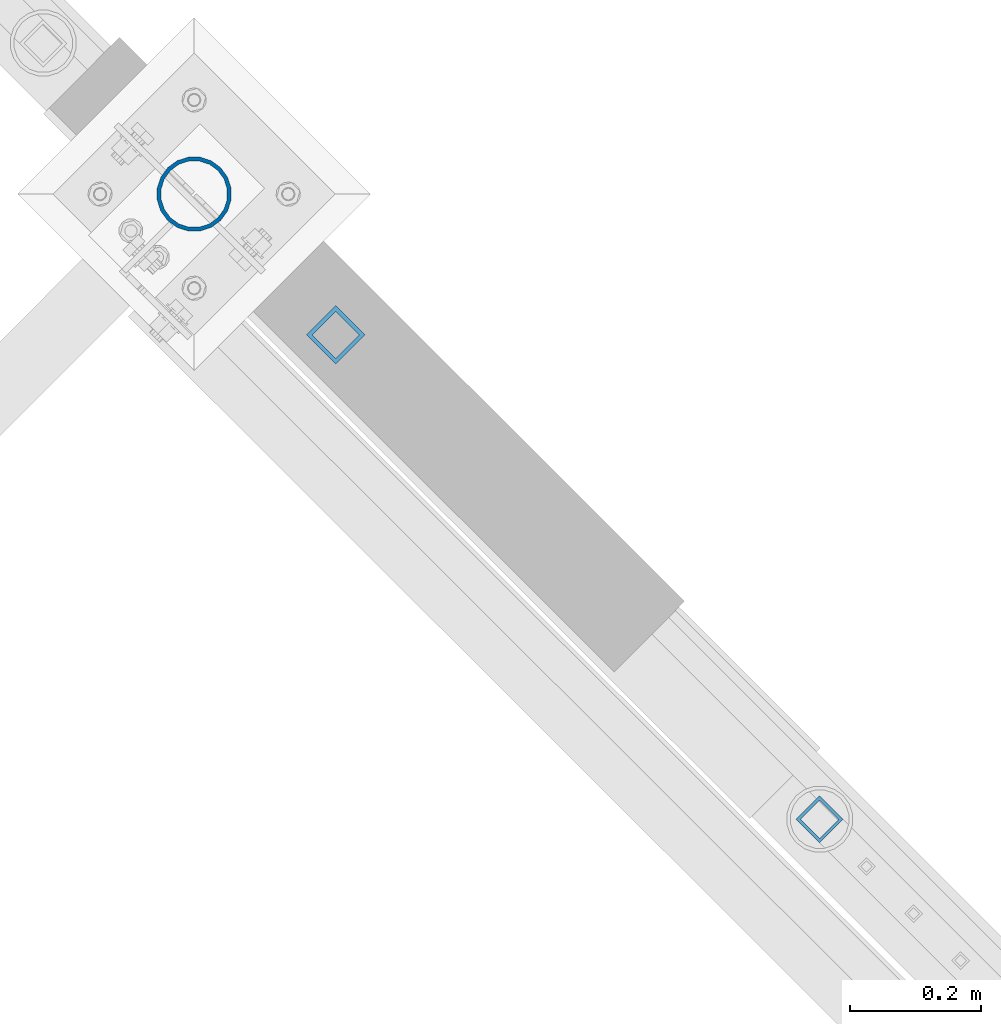
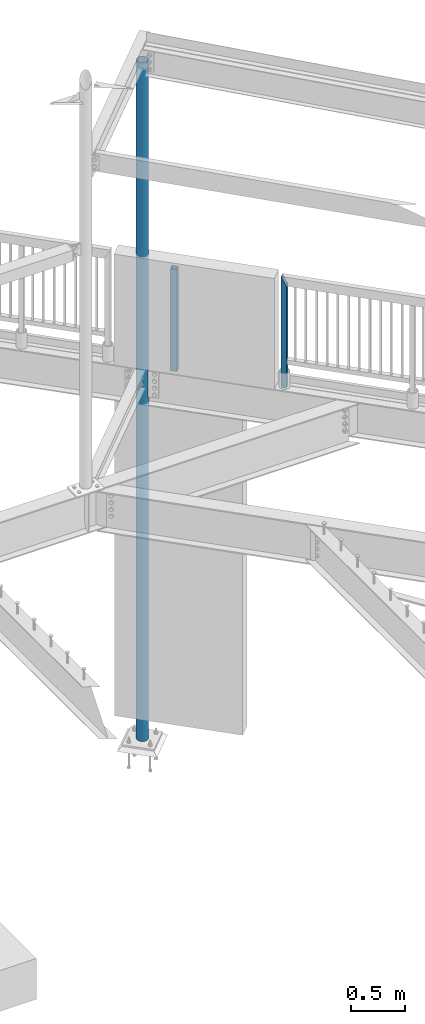
# One storey, part 129 of 975: 3 columns.
"""IFC2X3 building model written with IfcOpenShell, lengths in millimetres."""

from ifc_helpers import new_model, si_unit, frame, origin_with_axes, place, context, subcontext, project, spatial, faceted_brep, material, type_object, element, save


model = new_model("IFC2X3")

# Units and contexts
model_context = context("Model", 3, precision=1e-05, world=origin_with_axes())
body_context = subcontext(model_context, "Body", "Model", "MODEL_VIEW")
ifc_project = project(units=[si_unit("LENGTHUNIT", "METRE", prefix="MILLI"), si_unit("AREAUNIT", "SQUARE_METRE"), si_unit("VOLUMEUNIT", "CUBIC_METRE"), si_unit("MASSUNIT", "GRAM", prefix="KILO"), si_unit("TIMEUNIT", "SECOND"), si_unit("PLANEANGLEUNIT", "RADIAN"), si_unit("SOLIDANGLEUNIT", "STERADIAN"), si_unit("THERMODYNAMICTEMPERATUREUNIT", "DEGREE_CELSIUS"), si_unit("LUMINOUSINTENSITYUNIT", "LUMEN")], contexts=[model_context])

# Site, building, storey
site_placement = place(None, origin_with_axes())
site = spatial("IfcSite", under=ifc_project, at=site_placement, CompositionType="ELEMENT")
building_placement = place(site_placement, origin_with_axes())
building = spatial("IfcBuilding", under=site, at=building_placement, Name="Undefined", CompositionType="ELEMENT")
storey_placement = place(building_placement, origin_with_axes())
storey = spatial("IfcBuildingStorey", under=building, at=storey_placement, Name="Undefined", CompositionType="ELEMENT", Elevation=0.0)

# Columns
ifc_material_1 = material()
column_type_1 = type_object("IfcColumnType", Name="HSS2X2X.188_TUBES", PredefinedType="NOTDEFINED")
column_1_placement = place(storey_placement, frame((27510.8485036816, 21124.1770044978, 3937.00002018607), z_axis=(-0.707106781186601, 0.707106781186494, 2.36468622460961e-14), x_axis=(0.0, 0.0, 1.0)))
element("IfcColumn", 1, at=column_1_placement, inside=storey, type_object=column_type_1, material=ifc_material_1, Name="HANDRAIL", ObjectType="HSS2X2X.188_TUBES", context=body_context, shape_type="Brep", body=[
    faceted_brep([(0.0, 20.6374999999753, -20.6375000000298), (0.0, -20.6375000000153, -20.6375000000153), (1152.52497983932, -20.6374999999462, -20.6374999999525), (1152.52900291014, 20.6374999999462, -20.6374999999489), (0.0, -20.6374999999825, 20.6375000000335), (1235.07095675167, -20.6374999999462, 20.6374999999471), (0.0, 20.6375000000116, 20.6375000000189), (1235.07497982248, 20.6374999999534, 20.6374999999471), (0.0, 25.3999999999724, -25.4000000000342), (0.0, 25.400000000016, 25.4000000000196), (1244.59997982054, 25.399999999936, 25.3999999999351), (1143.00493131304, 25.399999999936, -25.3999999999387), (0.0, -25.399999999976, 25.4000000000378), (1244.59502834876, -25.399999999936, 25.3999999999369), (0.0, -25.400000000016, -25.4000000000196), (1143.0, -25.4000000000106, -25.4000000000451)], [[[0, 1, 2, 3]], [[1, 4, 5, 2]], [[4, 6, 7, 5]], [[6, 0, 3, 7]], [[8, 9, 10, 11]], [[9, 12, 13, 10]], [[12, 14, 15, 13]], [[14, 8, 11, 15]], [[13, 15, 11, 10], [5, 7, 3, 2]], [[14, 12, 9, 8], [6, 4, 1, 0]]]),
])
column_type_2 = type_object("IfcColumnType", Name="HSS2-1/2X2-1/2X1/4", PredefinedType="NOTDEFINED")
column_2_placement = place(storey_placement, frame((26771.9342768213, 21864.0941925499, 3937.0), z_axis=(0.707115470133164, 0.70709809213316, 0.0), x_axis=(0.0, 0.0, 1.0)))
element("IfcColumn", 2, at=column_2_placement, inside=storey, type_object=column_type_2, material=ifc_material_1, ObjectType="HSS2-1/2X2-1/2X1/4", context=body_context, shape_type="Brep", body=[
    faceted_brep([(0.0, 25.3999999999724, -25.4000000000342), (0.0, -25.400000000016, -25.4000000000196), (1143.0, -25.4000000000106, -25.4000000000451), (1143.0, 25.4000000000433, -25.4000000000087), (0.0, -25.399999999976, 25.4000000000378), (1143.0, -25.4000000000451, 25.4000000000087), (0.0, 25.400000000016, 25.4000000000196), (1143.0, 25.4000000000051, 25.4000000000378), (-5.45696821063757e-11, 31.7499999999909, -31.75000000002), (0.0, 31.7500000000127, 31.7500000000582), (1143.0, 31.7500000000127, 31.7500000000582), (1143.0, 31.7500000000546, -31.7500000000146), (0.0, -31.7500000000564, 31.7500000000073), (1143.0, -31.7500000000564, 31.7500000000073), (0.0, -31.7500000000146, -31.7500000000582), (1143.0, -31.7500000000146, -31.7500000000582)], [[[0, 1, 2, 3]], [[1, 4, 5, 2]], [[4, 6, 7, 5]], [[6, 0, 3, 7]], [[8, 9, 10, 11]], [[9, 12, 13, 10]], [[12, 14, 15, 13]], [[14, 8, 11, 15]], [[13, 15, 11, 10], [5, 7, 3, 2]], [[14, 12, 9, 8], [6, 4, 1, 0]]]),
])
ifc_material_2 = material(Name="STEEL/A53")
column_type_3 = type_object("IfcColumnType", Name="PIPE4STD", PredefinedType="NOTDEFINED")
column_3_placement = place(storey_placement, frame((26555.7, 22078.95, -266.7), z_axis=(0.707106781186548, 0.707106781186548, 0.0), x_axis=(0.0, 0.0, 1.0)))
element("IfcColumn", 3, at=column_3_placement, inside=storey, type_object=column_type_3, material=ifc_material_2, Name="COLUMN", ObjectType="PIPE4STD", context=body_context, shape_type="Brep", body=[
    faceted_brep([(4167.1875, -54.6357258964645, -15.8745019286362), (4167.1875, -48.6277098893543, -15.8001007257481), (3859.2125, -48.6277098893543, -15.8001007257481), (3859.2125, -54.6357258964645, -15.8745019286362), (3859.2125, -50.6274082885857, -3.17450192872639), (3859.2125, -56.6472082885693, -3.17450192872639), (4167.1875, -50.6274082885857, -3.17450192872639), (4167.1875, -56.6472082885693, -3.17450192872639), (19.0500000000025, -48.6277098894743, 15.8001007257917), (19.0500000000025, -41.3652007257897, 30.0535775067656), (7623.175, -41.3652007256869, 30.0535775066892), (7623.175, -48.6277098893561, 15.8001007257553), (19.0500000000025, -30.0535775067647, 41.3652007257915), (7623.175, -30.0535775066901, 41.3652007256896), (19.0500000000025, -15.8001007257899, 48.6277098894752), (7623.175, -15.8001007257526, 48.6277098893552), (19.0500000000025, 0.0, 51.1301999999996), (7623.175, 2.72848410531878e-12, 51.1301999998759), (19.0500000000025, 15.8001007257899, 48.6277098894752), (7623.175, 15.8001007257562, 48.6277098893552), (19.0500000000025, 30.0535775067647, 41.3652007257915), (7623.175, 30.0535775066937, 41.3652007256896), (19.0500000000025, 41.3652007257897, 30.0535775067656), (7623.175, 41.3652007256924, 30.0535775066892), (19.0500000000025, 48.6277098894743, 15.8001007257917), (7623.175, 48.6277098893615, 15.8001007257553), (19.0500000000025, 51.1301999999996, 0.0), (7623.175, 51.1301999998805, 0.0), (7623.175, 48.6277098893579, -15.8001007257553), (19.0500000000025, 48.6277098894743, -15.8001007257917), (3859.2125, 48.6277098893579, -15.8001007257553), (3859.2125, 50.6274082885893, -3.17450192871911), (4167.1875, 50.6274082885893, -3.17450192871911), (4167.1875, 48.6277098893579, -15.8001007257553), (19.0500000000025, 46.2353212285279, -33.5919271685161), (19.0500000000025, 54.3528799062678, -17.6603212285299), (7623.175, 54.3528799061378, -17.6603212284826), (7623.175, 46.2353212284206, -33.5919271684324), (19.0500000000025, 33.5919271685152, -46.235321228527), (7623.175, 33.5919271684352, -46.2353212284215), (19.0500000000025, 17.6603212285281, -54.3528799062697), (7623.175, 17.6603212284854, -54.3528799061387), (19.0500000000025, 0.0, -57.1500000000015), (7623.175, 9.09494701772928e-13, -57.1499999998705), (19.0500000000025, -17.6603212285281, -54.3528799062697), (7623.175, -17.6603212284817, -54.3528799061387), (19.0500000000025, -33.5919271685152, -46.235321228527), (7623.175, -33.5919271684315, -46.2353212284143), (19.0500000000025, -46.2353212285279, -33.5919271685161), (7623.175, -46.2353212284152, -33.5919271684324), (19.0500000000025, -54.3528799062678, -17.6603212285299), (7623.175, -54.3528799061323, -17.6603212284826), (19.0500000000025, -57.1499999999996, 0.0), (7623.175, -57.1499999998641, 0.0), (19.0500000000025, -54.3528799062678, 17.6603212285299), (7623.175, -54.3528799061341, 17.6603212284826), (19.0500000000025, -46.2353212285279, 33.5919271685161), (7623.175, -46.235321228417, 33.5919271684324), (19.0500000000025, -33.5919271685152, 46.235321228527), (7623.175, -33.5919271684315, 46.2353212284143), (19.0500000000025, -17.6603212285281, 54.3528799062697), (7623.175, -17.6603212284817, 54.3528799061387), (19.0500000000025, 0.0, 57.1500000000015), (7623.175, 2.72848410531878e-12, 57.1499999998632), (19.0500000000025, 17.6603212285281, 54.3528799062697), (7623.175, 17.6603212284854, 54.3528799061314), (19.0500000000025, 33.5919271685152, 46.235321228527), (7623.175, 33.5919271684352, 46.2353212284143), (19.0500000000025, 46.2353212285279, 33.5919271685161), (7623.175, 46.2353212284188, 33.5919271684324), (19.0500000000025, 54.3528799062678, 17.6603212285299), (7623.175, 54.352879906136, 17.6603212284826), (19.0500000000025, 57.1499999999996, 0.0), (7623.175, 57.1499999998678, 0.0), (3859.2125, 54.6357258964681, -15.8745019286289), (4167.1875, 54.6357258964681, -15.8745019286289), (4167.1875, 56.6472082885748, -3.17450192872639), (3859.2125, 56.6472082885748, -3.17450192872639), (19.0500000000025, 41.3652007257897, -30.0535775067656), (7623.175, 41.3652007256906, -30.0535775066892), (19.0500000000025, 30.0535775067647, -41.3652007257915), (7623.175, 30.0535775066937, -41.3652007256896), (19.0500000000025, 15.8001007257899, -48.6277098894752), (7623.175, 15.8001007257544, -48.6277098893552), (19.0500000000025, 0.0, -51.1301999999996), (7623.175, 4.54747350886464e-12, -51.1301999998759), (19.0500000000025, -15.8001007257899, -48.6277098894752), (7623.175, -15.800100725749, -48.6277098893552), (19.0500000000025, -30.0535775067647, -41.3652007257915), (7623.175, -30.0535775066901, -41.3652007256896), (19.0500000000025, -41.3652007257897, -30.0535775067656), (7623.175, -41.3652007256887, -30.0535775066892), (7623.175, -48.6277098893543, -15.8001007257481), (7623.175, -51.1301999998732, 0.0), (19.0500000000025, -51.1301999999996, 0.0), (19.0500000000025, -48.6277098894743, -15.8001007257917)], [[[0, 1, 2, 3]], [[3, 2, 4, 5]], [[5, 4, 6, 7]], [[7, 6, 1, 0]], [[8, 9, 10, 11]], [[9, 12, 13, 10]], [[12, 14, 15, 13]], [[14, 16, 17, 15]], [[16, 18, 19, 17]], [[18, 20, 21, 19]], [[20, 22, 23, 21]], [[22, 24, 25, 23]], [[24, 26, 27, 25]], [[28, 27, 26, 29, 30, 31, 32, 33]], [[34, 35, 36, 37]], [[38, 34, 37, 39]], [[40, 38, 39, 41]], [[42, 40, 41, 43]], [[44, 42, 43, 45]], [[46, 44, 45, 47]], [[48, 46, 47, 49]], [[50, 48, 49, 51]], [[52, 50, 51, 53], [3, 5, 7, 0]], [[54, 52, 53, 55]], [[56, 54, 55, 57]], [[58, 56, 57, 59]], [[60, 58, 59, 61]], [[62, 60, 61, 63]], [[64, 62, 63, 65]], [[66, 64, 65, 67]], [[68, 66, 67, 69]], [[70, 68, 69, 71]], [[72, 70, 71, 73]], [[35, 72, 73, 36], [74, 75, 76, 77]], [[32, 76, 75, 33]], [[31, 77, 76, 32]], [[30, 74, 77, 31]], [[33, 75, 74, 30]], [[29, 78, 79, 28, 33, 30]], [[78, 80, 81, 79]], [[80, 82, 83, 81]], [[82, 84, 85, 83]], [[84, 86, 87, 85]], [[86, 88, 89, 87]], [[88, 90, 91, 89]], [[49, 47, 45, 43, 41, 39, 37, 36, 73, 71, 69, 67, 65, 63, 61, 59, 57, 55, 53, 51], [10, 13, 15, 17, 19, 21, 23, 25, 27, 28, 79, 81, 83, 85, 87, 89, 91, 92, 93, 11]], [[94, 8, 11, 93]], [[54, 56, 58, 60, 62, 64, 66, 68, 70, 72, 35, 34, 38, 40, 42, 44, 46, 48, 50, 52], [95, 90, 88, 86, 84, 82, 80, 78, 29, 26, 24, 22, 20, 18, 16, 14, 12, 9, 8, 94]], [[92, 91, 90, 95, 2, 1]], [[2, 95, 94, 93, 92, 1, 6, 4]]]),
])

save(model, "model.ifc")
